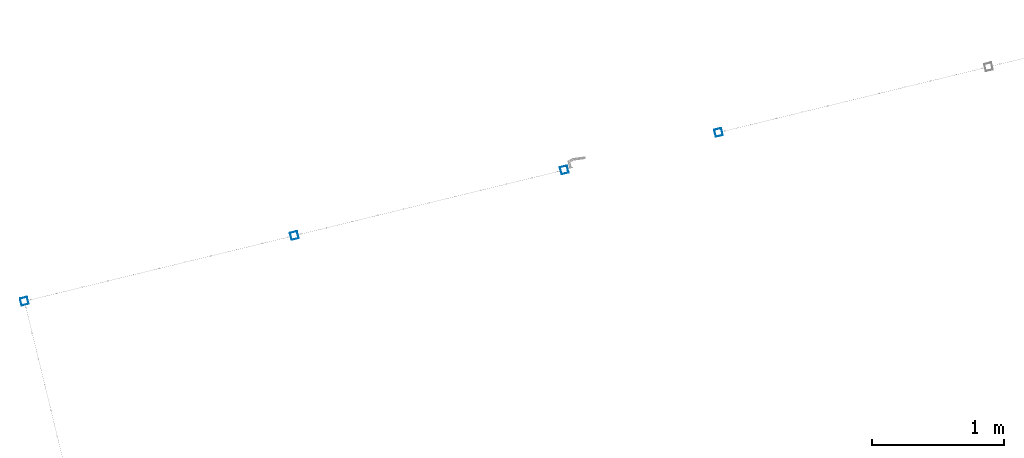
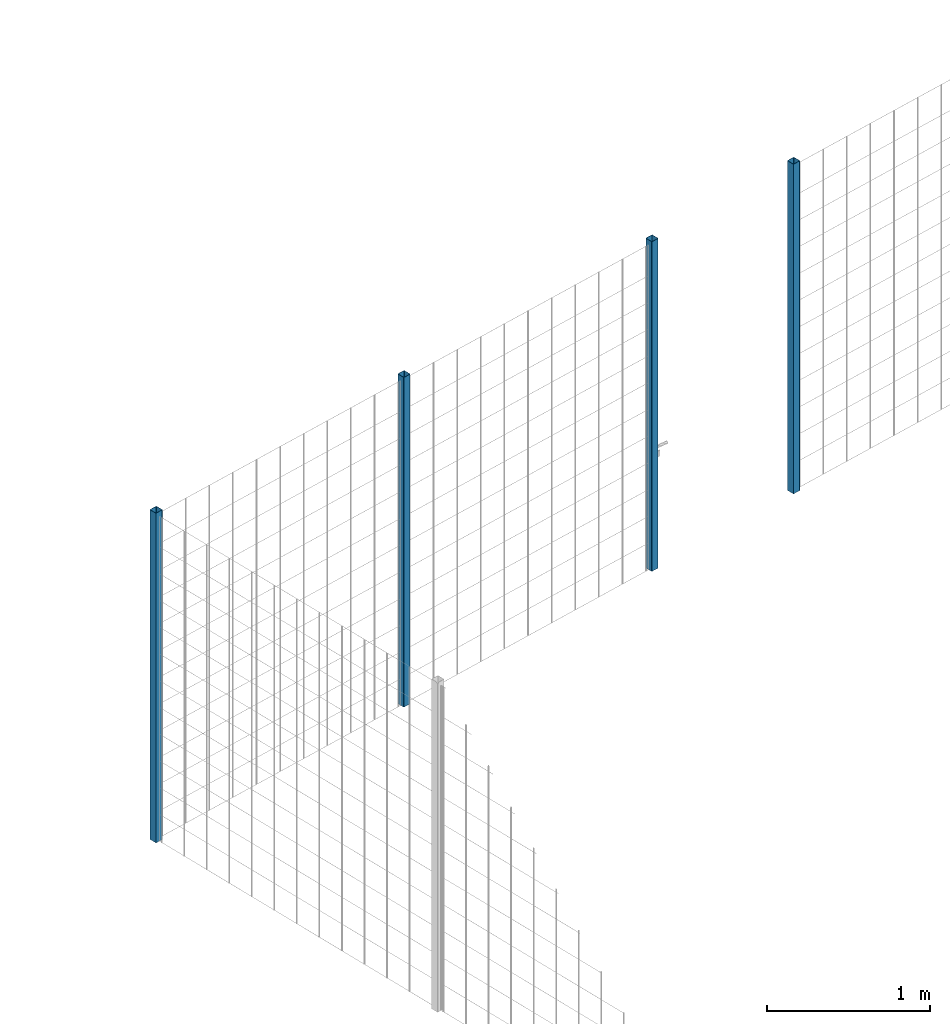
# One storey, part 3 of 10: 4 beams.
"""IFC2X3 building model written with IfcOpenShell, lengths in millimetres."""

import ifcopenshell
import ifcopenshell.guid

model = None  # the IFC model being written
_history = None  # IfcOwnerHistory: only IFC2X3 demands one
_inside = {}  # id of a spatial element -> (the spatial element, [elements in it])
_under = {}  # id of a project, library or spatial element -> (it, [spatial elements below it])
_declared = {}  # id of a project -> (the project, [libraries it declares])
_typed = {}  # id of a type object -> (the type object, [elements of that type])
_made_of = {}  # id of a material, layer set ... -> (it, [elements and type objects made of it])


def new_model(schema):
    """Start an empty IFC model of exactly this schema.

    Asked for "IFC4X3", IfcOpenShell would pick the latest addendum, in which some entities
    have other attributes; the version numbers below select the first issue.
    IFC2X3 requires an IfcOwnerHistory on every rooted entity: one is made here for all.
    """
    global model, _history
    if schema == "IFC4X3":
        model = ifcopenshell.file(schema_version=(4, 3, 0, 0))
    else:
        model = ifcopenshell.file(schema=schema)
    _inside.clear()
    _under.clear()
    _declared.clear()
    _typed.clear()
    _made_of.clear()
    _history = None
    if model.schema == "IFC2X3":
        org = make("IfcOrganization", Name="unknown")
        user = make(
            "IfcPersonAndOrganization",
            ThePerson=make("IfcPerson", FamilyName="unknown"),
            TheOrganization=org,
        )
        app = make(
            "IfcApplication",
            ApplicationDeveloper=org,
            Version="unknown",
            ApplicationFullName="unknown",
            ApplicationIdentifier="unknown",
        )
        _history = make(
            "IfcOwnerHistory",
            OwningUser=user,
            OwningApplication=app,
            ChangeAction="ADDED",
            CreationDate=0,
        )
    return model


def make(cls, **values):
    """One entity of the class cls with the attributes given. An attribute that is None is left unset."""
    return model.create_entity(
        cls, **{name: value for name, value in values.items() if value is not None}
    )


def entity(cls, *values):
    """Any entity or typed value of the class cls, its attributes in the order of the schema. None: left unset."""
    e = model.create_entity(cls)
    for i, value in enumerate(values):
        if value is not None:
            e[i] = value
    return e


def rooted(cls, **values):
    """An entity with a GlobalId (a new one), such as an element, a storey or a relation."""
    return make(cls, GlobalId=ifcopenshell.guid.new(), OwnerHistory=_history, **values)


def si_unit(unit_type, name, prefix=None):
    """IfcSIUnit, for example si_unit("LENGTHUNIT", "METRE", prefix="MILLI")."""
    return make("IfcSIUnit", UnitType=unit_type, Prefix=prefix, Name=name)


def converted_unit(unit_type, name, factor, base, dimensions=None, offset=None):
    """IfcConversionBasedUnit, such as the inch: factor (a typed value) times the base unit."""
    return make(
        "IfcConversionBasedUnit"
        if offset is None
        else "IfcConversionBasedUnitWithOffset",
        ConversionOffset=offset,
        Dimensions=None
        if dimensions is None
        else entity("IfcDimensionalExponents", *dimensions),
        UnitType=unit_type,
        Name=name,
        ConversionFactor=make(
            "IfcMeasureWithUnit", ValueComponent=factor, UnitComponent=base
        ),
    )


def derived_unit(unit_type, elements):
    """IfcDerivedUnit: a product of units, each with its exponent."""
    return make(
        "IfcDerivedUnit",
        Elements=[
            make("IfcDerivedUnitElement", Unit=unit, Exponent=power)
            for unit, power in elements
        ],
        UnitType=unit_type,
    )


def assignment(units):
    """IfcUnitAssignment: the units of a project."""
    return None if units is None else make("IfcUnitAssignment", Units=units)


def point(xyz):
    """IfcCartesianPoint."""
    return None if xyz is None else make("IfcCartesianPoint", Coordinates=xyz)


def direction(xyz):
    """IfcDirection."""
    return None if xyz is None else make("IfcDirection", DirectionRatios=xyz)


def frame(location, z_axis=None, x_axis=None):
    """IfcAxis2Placement3D, a coordinate frame: its origin and axes. An axis left out is left unset."""
    return make(
        "IfcAxis2Placement3D",
        Location=point(location),
        Axis=direction(z_axis),
        RefDirection=direction(x_axis),
    )


def frame_2d(location, x_axis=None):
    """IfcAxis2Placement2D, a coordinate frame in the plane: its origin and x axis."""
    return make(
        "IfcAxis2Placement2D", Location=point(location), RefDirection=direction(x_axis)
    )


def origin():
    """The frame at (0, 0, 0) with its axes left unset."""
    return frame((0.0, 0.0, 0.0))


def place(relative_to, where):
    """IfcLocalPlacement: puts the frame where relative to a parent placement (None: the world)."""
    return make(
        "IfcLocalPlacement", PlacementRelTo=relative_to, RelativePlacement=where
    )


def context(
    kind, dimensions, precision=None, world=None, true_north=None, identifier=None
):
    """IfcGeometricRepresentationContext, for example the 3D "Model" context."""
    return make(
        "IfcGeometricRepresentationContext",
        ContextIdentifier=identifier,
        ContextType=kind,
        CoordinateSpaceDimension=dimensions,
        Precision=precision,
        WorldCoordinateSystem=world,
        TrueNorth=true_north,
    )


def subcontext(parent, identifier, kind, view, scale=None):
    """IfcGeometricRepresentationSubContext, for example "Body" below "Model"."""
    return make(
        "IfcGeometricRepresentationSubContext",
        ContextIdentifier=identifier,
        ContextType=kind,
        ParentContext=parent,
        TargetScale=scale,
        TargetView=view,
    )


def project(units=None, contexts=None):
    """IfcProject with its units and contexts."""
    return rooted(
        "IfcProject",
        Name="project",
        RepresentationContexts=contexts,
        UnitsInContext=assignment(units),
    )


def spatial(cls, under=None, at=None, **own):
    """A site, building, storey or space (cls), placed at a placement, below another one or the project."""
    s = rooted(cls, ObjectPlacement=at, **own)
    if under is not None:
        _under.setdefault(under.id(), (under, []))[1].append(s)
    return s


def polyline(points):
    """IfcPolyline through the points."""
    return make("IfcPolyline", Points=[point(p) for p in points])


def circle_curve(where, radius):
    """IfcCircle in the frame where."""
    return make("IfcCircle", Position=where, Radius=radius)


def parameter(value):
    """IfcParameterValue: where a trimmed curve begins or ends, as a parameter of its basis curve."""
    return model.create_entity("IfcParameterValue", value)


def trimmed(basis, trim1, trim2, sense, master):
    """IfcTrimmedCurve: the piece of a basis curve between two trims."""
    return make(
        "IfcTrimmedCurve",
        BasisCurve=basis,
        Trim1=trim1,
        Trim2=trim2,
        SenseAgreement=sense,
        MasterRepresentation=master,
    )


def segment(curve, same_sense, transition):
    """IfcCompositeCurveSegment."""
    return make(
        "IfcCompositeCurveSegment",
        Transition=transition,
        SameSense=same_sense,
        ParentCurve=curve,
    )


def composite_curve(segments, self_intersect=None):
    """IfcCompositeCurve: segments joined end to end."""
    return make("IfcCompositeCurve", Segments=segments, SelfIntersect=self_intersect)


def outline(outer, holes=None, kind="AREA"):
    """IfcArbitraryClosedProfileDef: a profile drawn as a closed curve; with holes, ...WithVoids."""
    if holes is None:
        return make("IfcArbitraryClosedProfileDef", ProfileType=kind, OuterCurve=outer)
    return make(
        "IfcArbitraryProfileDefWithVoids",
        ProfileType=kind,
        OuterCurve=outer,
        InnerCurves=holes,
    )


def extrude(swept, where, along, depth):
    """IfcExtrudedAreaSolid: the profile swept, set in the frame where, extruded along a direction by depth."""
    return make(
        "IfcExtrudedAreaSolid",
        SweptArea=swept,
        Position=where,
        ExtrudedDirection=direction(along),
        Depth=depth,
    )


def shape(context_of_items, identifier, shape_type, items):
    """IfcShapeRepresentation: the items that make up one representation, for example the "Body"."""
    return make(
        "IfcShapeRepresentation",
        ContextOfItems=context_of_items,
        RepresentationIdentifier=identifier,
        RepresentationType=shape_type,
        Items=items,
    )


def material(Name=None, Category=None):
    """IfcMaterial."""
    return make("IfcMaterial", Name=Name, Category=Category)


def made_of(thing, what):
    """Note that an element or type object is made of a material, layer set ...; save() writes the relation."""
    if what is not None:
        _made_of.setdefault(what.id(), (what, []))[1].append(thing)
    return thing


def type_object(cls, material=None, **own):
    """A type object (cls), such as IfcWallType, which elements share."""
    return made_of(rooted(cls, **own), material)


def element(
    cls,
    number,
    at=None,
    inside=None,
    cuts=None,
    type_object=None,
    material=None,
    context=None,
    identifier="Body",
    shape_type=None,
    held_by="IfcProductDefinitionShape",
    body=None,
    shapes=None,
    **own,
):
    """One element of the class cls, such as IfcWall. Its Tag is "e" and its number.

    at: its placement. inside: the storey or other place that contains it. cuts: it is an
    opening in that element (IfcRelVoidsElement). A single representation is given by context,
    identifier, shape_type and body (its items); several are given by shapes. held_by: the class
    of the entity that holds the representations. save() writes the other relations.
    """
    e = rooted(cls, Tag="e%d" % number, ObjectPlacement=at, **own)
    if body is not None:
        shapes = [shape(context, identifier, shape_type, body)]
    if shapes is not None:
        e.Representation = make(held_by, Representations=shapes)
    if inside is not None:
        _inside.setdefault(inside.id(), (inside, []))[1].append(e)
    if cuts is not None:
        rooted(
            "IfcRelVoidsElement", RelatingBuildingElement=cuts, RelatedOpeningElement=e
        )
    if type_object is not None:
        _typed.setdefault(type_object.id(), (type_object, []))[1].append(e)
    return made_of(e, material)


def aggregate(whole, parts):
    """IfcRelAggregates: a whole, such as a stair, and the parts it consists of."""
    return rooted("IfcRelAggregates", RelatingObject=whole, RelatedObjects=parts)


def save(model, path):
    """Write the relations noted so far, then the file.

    IfcRelAggregates (storeys below a building ...), IfcRelContainedInSpatialStructure (elements
    in a storey), IfcRelDefinesByType, IfcRelAssociatesMaterial and IfcRelDeclares: one each for
    every whole, place, type object, material and project.
    """
    for whole, parts in _under.values():
        aggregate(whole, parts)
    for where, things in _inside.values():
        rooted(
            "IfcRelContainedInSpatialStructure",
            RelatedElements=things,
            RelatingStructure=where,
        )
    for kind, things in _typed.values():
        rooted("IfcRelDefinesByType", RelatedObjects=things, RelatingType=kind)
    for what, things in _made_of.values():
        rooted("IfcRelAssociatesMaterial", RelatedObjects=things, RelatingMaterial=what)
    for by, libraries in _declared.values():
        rooted("IfcRelDeclares", RelatingContext=by, RelatedDefinitions=libraries)
    model.write(path)


model = new_model("IFC2X3")

# Units and contexts
model_context = context("Model", 3, precision=0.01, world=origin(), true_north=direction((6.12303176911189e-17, 1.0)))
body_context = subcontext(model_context, "Body", "Model", "MODEL_VIEW")
ifc_project = project(units=[si_unit("LENGTHUNIT", "METRE", prefix="MILLI"), si_unit("AREAUNIT", "SQUARE_METRE"), si_unit("VOLUMEUNIT", "CUBIC_METRE"), converted_unit("PLANEANGLEUNIT", "DEGREE", entity("IfcRatioMeasure", 0.0174532925199433), si_unit("PLANEANGLEUNIT", "RADIAN"), dimensions=[0, 0, 0, 0, 0, 0, 0]), si_unit("MASSUNIT", "GRAM", prefix="KILO"), derived_unit("MASSDENSITYUNIT", [(si_unit("MASSUNIT", "GRAM", prefix="KILO"), 1), (si_unit("LENGTHUNIT", "METRE"), -3)]), derived_unit("MOMENTOFINERTIAUNIT", [(si_unit("LENGTHUNIT", "METRE"), 4)]), si_unit("TIMEUNIT", "SECOND"), si_unit("FREQUENCYUNIT", "HERTZ"), si_unit("THERMODYNAMICTEMPERATUREUNIT", "DEGREE_CELSIUS"), derived_unit("THERMALTRANSMITTANCEUNIT", [(si_unit("MASSUNIT", "GRAM", prefix="KILO"), 1), (si_unit("THERMODYNAMICTEMPERATUREUNIT", "KELVIN"), -1), (si_unit("TIMEUNIT", "SECOND"), -3)]), derived_unit("VOLUMETRICFLOWRATEUNIT", [(si_unit("LENGTHUNIT", "METRE"), 3), (si_unit("TIMEUNIT", "SECOND"), -1)]), derived_unit("MASSFLOWRATEUNIT", [(si_unit("MASSUNIT", "GRAM", prefix="KILO"), 1), (si_unit("TIMEUNIT", "SECOND"), -1)]), derived_unit("ROTATIONALFREQUENCYUNIT", [(si_unit("TIMEUNIT", "SECOND"), -1)]), si_unit("ELECTRICCURRENTUNIT", "AMPERE"), si_unit("ELECTRICVOLTAGEUNIT", "VOLT"), si_unit("POWERUNIT", "WATT"), si_unit("FORCEUNIT", "NEWTON", prefix="KILO"), si_unit("ILLUMINANCEUNIT", "LUX"), si_unit("LUMINOUSFLUXUNIT", "LUMEN"), si_unit("LUMINOUSINTENSITYUNIT", "CANDELA"), derived_unit("USERDEFINED", [(si_unit("MASSUNIT", "GRAM", prefix="KILO"), -1), (si_unit("LENGTHUNIT", "METRE"), -2), (si_unit("TIMEUNIT", "SECOND"), 3), (si_unit("LUMINOUSFLUXUNIT", "LUMEN"), 1)]), derived_unit("LINEARVELOCITYUNIT", [(si_unit("LENGTHUNIT", "METRE"), 1), (si_unit("TIMEUNIT", "SECOND"), -1)]), si_unit("PRESSUREUNIT", "PASCAL"), derived_unit("USERDEFINED", [(si_unit("LENGTHUNIT", "METRE"), -2), (si_unit("MASSUNIT", "GRAM", prefix="KILO"), 1), (si_unit("TIMEUNIT", "SECOND"), -2)]), derived_unit("LINEARFORCEUNIT", [(si_unit("MASSUNIT", "GRAM", prefix="KILO"), 1), (si_unit("LENGTHUNIT", "METRE"), 1), (si_unit("TIMEUNIT", "SECOND"), -2), (si_unit("LENGTHUNIT", "METRE"), -1)]), derived_unit("PLANARFORCEUNIT", [(si_unit("MASSUNIT", "GRAM", prefix="KILO"), 1), (si_unit("LENGTHUNIT", "METRE"), 1), (si_unit("TIMEUNIT", "SECOND"), -2), (si_unit("LENGTHUNIT", "METRE"), -2)])], contexts=[model_context])

# Site, building, storey
site_placement = place(None, frame((19171.746869958, -72498.5768491146, 0.0), z_axis=(0.0, 0.0, 1.0), x_axis=(0.971695960795463, 0.236234967296933, 0.0)))
site = spatial("IfcSite", under=ifc_project, at=site_placement, CompositionType="ELEMENT")
building_placement = place(site_placement, origin())
building = spatial("IfcBuilding", under=site, at=building_placement, CompositionType="ELEMENT")
storey_placement = place(building_placement, origin())
storey = spatial("IfcBuildingStorey", under=building, at=storey_placement, CompositionType="ELEMENT", Elevation=0.0)

# Beams
ifc_material = material()
beam_type = type_object("IfcBeamType", PredefinedType="NOTDEFINED")
beam_1_placement = place(storey_placement, frame((170.904727764104, 5570.90472776409, 0.0), z_axis=(1.0, 0.0, 0.0), x_axis=(0.0, 0.0, -1.0)))
element("IfcBeam", 1, at=beam_1_placement, inside=storey, type_object=beam_type, material=ifc_material, context=body_context, shape_type="SweptSolid", body=[
    extrude(outline(composite_curve([segment(trimmed(circle_curve(frame_2d((24.6999999999997, -24.6999999999999), x_axis=(1.0, 0.0)), 2.79999999999974), [parameter(269.999999999999)], [parameter(1.32311074748882e-12)], True, "PARAMETER"), True, "CONTINUOUS"), segment(polyline([(27.4999999999991, -24.6999999999999), (27.4999999999981, 24.7000000000002)]), True, "CONTINUOUS"), segment(trimmed(circle_curve(frame_2d((24.6999999999999, 24.7000000000002), x_axis=(1.0, 0.0)), 2.79999999999845), [parameter(1.32311074748882e-12)], [parameter(90.0000000000001)], True, "PARAMETER"), True, "CONTINUOUS"), segment(polyline([(24.6999999999999, 27.4999999999987), (-24.6999999999997, 27.4999999999987)]), True, "CONTINUOUS"), segment(trimmed(circle_curve(frame_2d((-24.6999999999997, 24.7000000000002), x_axis=(1.0, 0.0)), 2.79999999999845), [parameter(90.0000000000001)], [parameter(180.0)], True, "PARAMETER"), True, "CONTINUOUS"), segment(polyline([(-27.499999999998, 24.7000000000002), (-27.4999999999981, -24.6999999999999)]), True, "CONTINUOUS"), segment(trimmed(circle_curve(frame_2d((-24.6999999999999, -24.6999999999999), x_axis=(1.0, 0.0)), 2.79999999999845), [parameter(180.0)], [parameter(269.999999999998)], True, "PARAMETER"), True, "CONTINUOUS"), segment(polyline([(-24.6999999999999, -27.4999999999983), (24.6999999999997, -27.4999999999996)]), True, "CONTINUOUS")], self_intersect=False), holes=[composite_curve([segment(polyline([(23.3000000000001, -26.1000000000001), (-23.3000000000002, -26.0999999999995)]), True, "CONTINUOUS"), segment(trimmed(circle_curve(frame_2d((-23.3000000000002, -23.2999999999998), x_axis=(1.0, 0.0)), 2.79999999999973), [parameter(180.0)], [parameter(270.0)], True, "PARAMETER"), False, "CONTINUOUS"), segment(polyline([(-26.1000000000006, -23.2999999999998), (-26.1000000000005, 23.3000000000002)]), True, "CONTINUOUS"), segment(trimmed(circle_curve(frame_2d((-23.3000000000001, 23.3000000000002), x_axis=(1.0, 0.0)), 2.79999999999973), [parameter(90.0000000000004)], [parameter(180.0)], True, "PARAMETER"), False, "CONTINUOUS"), segment(polyline([(-23.3000000000001, 26.0999999999999), (23.2999999999991, 26.0999999999999)]), True, "CONTINUOUS"), segment(trimmed(circle_curve(frame_2d((23.2999999999991, 23.3000000000002), x_axis=(1.0, 0.0)), 2.79999999999973), [parameter(3.56222124323914e-13)], [parameter(90.0000000000004)], True, "PARAMETER"), False, "CONTINUOUS"), segment(polyline([(26.0999999999995, 23.3000000000002), (26.0999999999994, -23.2999999999998)]), True, "CONTINUOUS"), segment(trimmed(circle_curve(frame_2d((23.299999999999, -23.2999999999998), x_axis=(1.0, 0.0)), 2.80000000000034), [parameter(270.0)], [parameter(4.57999874130747e-13)], True, "PARAMETER"), False, "CONTINUOUS")], self_intersect=False)]), frame((-2465.97922445826, 29.095272235914, 29.0952722359156), z_axis=(1.0, 0.0, 0.0), x_axis=(0.0, 1.0, 0.0)), (0.0, 0.0, 1.0), 2465.97922445826),
])
beam_2_placement = place(storey_placement, frame((2270.9047277641, 5570.90472776409, 0.0), z_axis=(1.0, 0.0, 0.0), x_axis=(0.0, 0.0, -1.0)))
element("IfcBeam", 2, at=beam_2_placement, inside=storey, type_object=beam_type, material=ifc_material, context=body_context, shape_type="SweptSolid", body=[
    extrude(outline(composite_curve([segment(trimmed(circle_curve(frame_2d((24.6999999999987, -24.6999999999999), x_axis=(1.0, 0.0)), 2.79999999999974), [parameter(269.999999999999)], [parameter(1.32311074748882e-12)], True, "PARAMETER"), True, "CONTINUOUS"), segment(polyline([(27.499999999998, -24.6999999999996), (27.4999999999971, 24.7000000000005)]), True, "CONTINUOUS"), segment(trimmed(circle_curve(frame_2d((24.6999999999988, 24.7000000000003), x_axis=(1.0, 0.0)), 2.79999999999845), [parameter(1.32311074748882e-12)], [parameter(90.0000000000001)], True, "PARAMETER"), True, "CONTINUOUS"), segment(polyline([(24.6999999999988, 27.4999999999991), (-24.7000000000008, 27.499999999999)]), True, "CONTINUOUS"), segment(trimmed(circle_curve(frame_2d((-24.7000000000008, 24.7000000000004), x_axis=(1.0, 0.0)), 2.79999999999845), [parameter(90.0000000000001)], [parameter(180.0)], True, "PARAMETER"), True, "CONTINUOUS"), segment(polyline([(-27.4999999999991, 24.7000000000004), (-27.4999999999992, -24.6999999999995)]), True, "CONTINUOUS"), segment(trimmed(circle_curve(frame_2d((-24.7000000000009, -24.6999999999997), x_axis=(1.0, 0.0)), 2.79999999999845), [parameter(180.0)], [parameter(269.999999999998)], True, "PARAMETER"), True, "CONTINUOUS"), segment(polyline([(-24.7000000000009, -27.499999999998), (24.6999999999986, -27.4999999999992)]), True, "CONTINUOUS")], self_intersect=False), holes=[composite_curve([segment(polyline([(23.299999999999, -26.0999999999998), (-23.3000000000013, -26.0999999999992)]), True, "CONTINUOUS"), segment(trimmed(circle_curve(frame_2d((-23.3000000000013, -23.2999999999995), x_axis=(1.0, 0.0)), 2.79999999999973), [parameter(180.0)], [parameter(270.0)], True, "PARAMETER"), False, "CONTINUOUS"), segment(polyline([(-26.1000000000017, -23.2999999999995), (-26.1000000000016, 23.3000000000005)]), True, "CONTINUOUS"), segment(trimmed(circle_curve(frame_2d((-23.3000000000011, 23.3000000000004), x_axis=(1.0, 0.0)), 2.79999999999973), [parameter(90.0000000000004)], [parameter(180.0)], True, "PARAMETER"), False, "CONTINUOUS"), segment(polyline([(-23.3000000000011, 26.1000000000004), (23.299999999998, 26.1000000000002)]), True, "CONTINUOUS"), segment(trimmed(circle_curve(frame_2d((23.299999999998, 23.3000000000003), x_axis=(1.0, 0.0)), 2.79999999999973), [parameter(3.56222124323914e-13)], [parameter(90.0000000000004)], True, "PARAMETER"), False, "CONTINUOUS"), segment(polyline([(26.0999999999985, 23.3000000000006), (26.0999999999983, -23.2999999999994)]), True, "CONTINUOUS"), segment(trimmed(circle_curve(frame_2d((23.2999999999979, -23.2999999999996), x_axis=(1.0, 0.0)), 2.80000000000034), [parameter(270.0)], [parameter(4.57999874130747e-13)], True, "PARAMETER"), False, "CONTINUOUS")], self_intersect=False)]), frame((-2465.97922445826, 29.0952722359151, 29.0952722359151), z_axis=(1.0, 0.0, 0.0), x_axis=(0.0, 1.0, 0.0)), (0.0, 0.0, 1.0), 2465.97922445826),
])
beam_3_placement = place(storey_placement, frame((4370.9047277641, 5570.90472776409, 0.0), z_axis=(1.0, 0.0, 0.0), x_axis=(0.0, 0.0, -1.0)))
element("IfcBeam", 3, at=beam_3_placement, inside=storey, type_object=beam_type, material=ifc_material, context=body_context, shape_type="SweptSolid", body=[
    extrude(outline(composite_curve([segment(trimmed(circle_curve(frame_2d((24.6999999999997, -24.6999999999999), x_axis=(1.0, 0.0)), 2.79999999999974), [parameter(269.999999999999)], [parameter(1.32311074748882e-12)], True, "PARAMETER"), True, "CONTINUOUS"), segment(polyline([(27.4999999999991, -24.6999999999999), (27.4999999999981, 24.7000000000003)]), True, "CONTINUOUS"), segment(trimmed(circle_curve(frame_2d((24.6999999999999, 24.7000000000003), x_axis=(1.0, 0.0)), 2.79999999999845), [parameter(1.32311074748882e-12)], [parameter(90.0000000000001)], True, "PARAMETER"), True, "CONTINUOUS"), segment(polyline([(24.6999999999999, 27.4999999999986), (-24.6999999999997, 27.4999999999987)]), True, "CONTINUOUS"), segment(trimmed(circle_curve(frame_2d((-24.6999999999997, 24.7000000000004), x_axis=(1.0, 0.0)), 2.79999999999845), [parameter(90.0000000000001)], [parameter(180.0)], True, "PARAMETER"), True, "CONTINUOUS"), segment(polyline([(-27.499999999998, 24.7000000000004), (-27.4999999999981, -24.6999999999997)]), True, "CONTINUOUS"), segment(trimmed(circle_curve(frame_2d((-24.6999999999999, -24.6999999999997), x_axis=(1.0, 0.0)), 2.79999999999845), [parameter(180.0)], [parameter(269.999999999998)], True, "PARAMETER"), True, "CONTINUOUS"), segment(polyline([(-24.6999999999999, -27.4999999999986), (24.6999999999997, -27.4999999999998)]), True, "CONTINUOUS")], self_intersect=False), holes=[composite_curve([segment(polyline([(23.3000000000001, -26.1000000000001), (-23.3000000000002, -26.0999999999994)]), True, "CONTINUOUS"), segment(trimmed(circle_curve(frame_2d((-23.3000000000002, -23.3000000000001), x_axis=(1.0, 0.0)), 2.79999999999973), [parameter(180.0)], [parameter(270.0)], True, "PARAMETER"), False, "CONTINUOUS"), segment(polyline([(-26.1000000000006, -23.2999999999995), (-26.1000000000005, 23.3000000000002)]), True, "CONTINUOUS"), segment(trimmed(circle_curve(frame_2d((-23.3000000000001, 23.3000000000002), x_axis=(1.0, 0.0)), 2.79999999999973), [parameter(90.0000000000004)], [parameter(180.0)], True, "PARAMETER"), False, "CONTINUOUS"), segment(polyline([(-23.3000000000001, 26.1000000000001), (23.2999999999991, 26.1)]), True, "CONTINUOUS"), segment(trimmed(circle_curve(frame_2d((23.2999999999991, 23.3000000000001), x_axis=(1.0, 0.0)), 2.79999999999973), [parameter(3.56222124323914e-13)], [parameter(90.0000000000004)], True, "PARAMETER"), False, "CONTINUOUS"), segment(polyline([(26.0999999999995, 23.3000000000001), (26.0999999999994, -23.2999999999996)]), True, "CONTINUOUS"), segment(trimmed(circle_curve(frame_2d((23.299999999999, -23.3000000000002), x_axis=(1.0, 0.0)), 2.80000000000034), [parameter(270.0)], [parameter(4.57999874130747e-13)], True, "PARAMETER"), False, "CONTINUOUS")], self_intersect=False)]), frame((-2465.97922445826, 29.095272235914, 29.0952722359151), z_axis=(1.0, 0.0, 0.0), x_axis=(0.0, 1.0, 0.0)), (0.0, 0.0, 1.0), 2465.97922445826),
])
beam_4_placement = place(storey_placement, frame((5570.9047277641, 5570.90472776409, 0.0), z_axis=(1.0, 0.0, 0.0), x_axis=(0.0, 0.0, -1.0)))
element("IfcBeam", 4, at=beam_4_placement, inside=storey, type_object=beam_type, material=ifc_material, context=body_context, shape_type="SweptSolid", body=[
    extrude(outline(composite_curve([segment(trimmed(circle_curve(frame_2d((24.6999999999997, -24.6999999999999), x_axis=(1.0, 0.0)), 2.79999999999974), [parameter(269.999999999999)], [parameter(1.32311074748882e-12)], True, "PARAMETER"), True, "CONTINUOUS"), segment(polyline([(27.4999999999991, -24.6999999999988), (27.4999999999981, 24.7000000000008)]), True, "CONTINUOUS"), segment(trimmed(circle_curve(frame_2d((24.6999999999999, 24.7000000000008), x_axis=(1.0, 0.0)), 2.79999999999845), [parameter(1.32311074748882e-12)], [parameter(90.0000000000001)], True, "PARAMETER"), True, "CONTINUOUS"), segment(polyline([(24.6999999999999, 27.4999999999991), (-24.6999999999997, 27.4999999999992)]), True, "CONTINUOUS"), segment(trimmed(circle_curve(frame_2d((-24.6999999999997, 24.7000000000009), x_axis=(1.0, 0.0)), 2.79999999999845), [parameter(90.0000000000001)], [parameter(180.0)], True, "PARAMETER"), True, "CONTINUOUS"), segment(polyline([(-27.499999999998, 24.700000000001), (-27.4999999999981, -24.6999999999997)]), True, "CONTINUOUS"), segment(trimmed(circle_curve(frame_2d((-24.6999999999999, -24.6999999999997), x_axis=(1.0, 0.0)), 2.79999999999845), [parameter(180.0)], [parameter(269.999999999998)], True, "PARAMETER"), True, "CONTINUOUS"), segment(polyline([(-24.6999999999999, -27.499999999998), (24.6999999999997, -27.4999999999992)]), True, "CONTINUOUS")], self_intersect=False), holes=[composite_curve([segment(polyline([(23.3000000000001, -26.0999999999995), (-23.3000000000002, -26.0999999999994)]), True, "CONTINUOUS"), segment(trimmed(circle_curve(frame_2d((-23.3000000000002, -23.299999999999), x_axis=(1.0, 0.0)), 2.79999999999973), [parameter(180.0)], [parameter(270.0)], True, "PARAMETER"), False, "CONTINUOUS"), segment(polyline([(-26.1000000000006, -23.299999999999), (-26.1000000000005, 23.3000000000013)]), True, "CONTINUOUS"), segment(trimmed(circle_curve(frame_2d((-23.3000000000001, 23.3000000000013), x_axis=(1.0, 0.0)), 2.79999999999973), [parameter(90.0000000000004)], [parameter(180.0)], True, "PARAMETER"), False, "CONTINUOUS"), segment(polyline([(-23.3000000000001, 26.1000000000006), (23.2999999999991, 26.1000000000005)]), True, "CONTINUOUS"), segment(trimmed(circle_curve(frame_2d((23.2999999999991, 23.3000000000011), x_axis=(1.0, 0.0)), 2.79999999999973), [parameter(3.56222124323914e-13)], [parameter(90.0000000000004)], True, "PARAMETER"), False, "CONTINUOUS"), segment(polyline([(26.0999999999995, 23.3000000000011), (26.0999999999994, -23.2999999999991)]), True, "CONTINUOUS"), segment(trimmed(circle_curve(frame_2d((23.299999999999, -23.2999999999991), x_axis=(1.0, 0.0)), 2.80000000000034), [parameter(270.0)], [parameter(4.57999874130747e-13)], True, "PARAMETER"), False, "CONTINUOUS")], self_intersect=False)]), frame((-2465.97922445826, 29.0952722359129, 29.0952722359151), z_axis=(1.0, 0.0, 0.0), x_axis=(0.0, 1.0, 0.0)), (0.0, 0.0, 1.0), 2465.97922445826),
])

save(model, "model.ifc")
